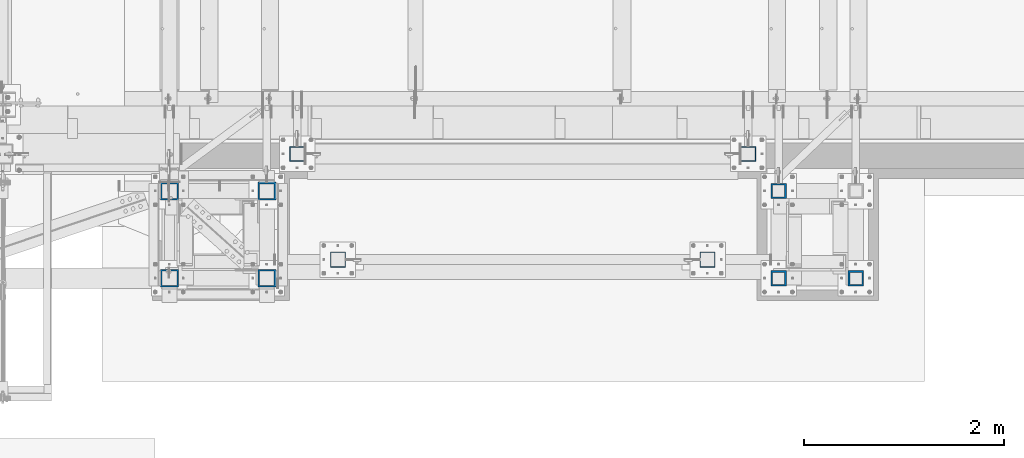
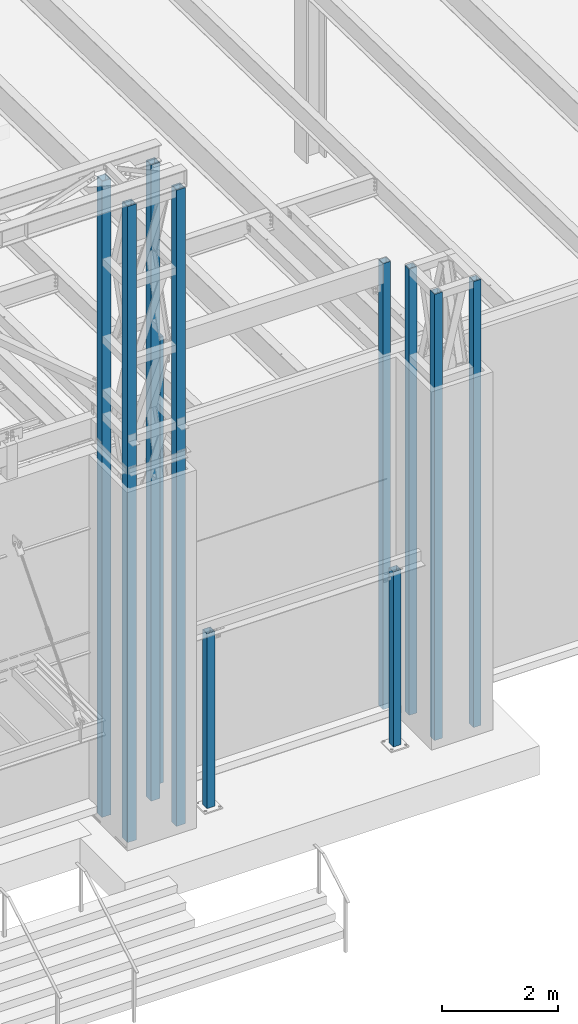
# One storey, part 895 of 1763: 11 columns, 6 elements without a shape of their own.
"""IFC2X3 building model written with IfcOpenShell, lengths in millimetres."""

from ifc_helpers import new_model, si_unit, frame, origin_with_axes, place, context, subcontext, project, spatial, faceted_brep, material, type_object, element, aggregate, save


model = new_model("IFC2X3")

# Units and contexts
model_context = context("Model", 3, precision=1e-05, world=origin_with_axes())
body_context = subcontext(model_context, "Body", "Model", "MODEL_VIEW")
ifc_project = project(units=[si_unit("LENGTHUNIT", "METRE", prefix="MILLI"), si_unit("AREAUNIT", "SQUARE_METRE"), si_unit("VOLUMEUNIT", "CUBIC_METRE"), si_unit("MASSUNIT", "GRAM", prefix="KILO"), si_unit("TIMEUNIT", "SECOND"), si_unit("PLANEANGLEUNIT", "RADIAN"), si_unit("SOLIDANGLEUNIT", "STERADIAN"), si_unit("THERMODYNAMICTEMPERATUREUNIT", "DEGREE_CELSIUS"), si_unit("LUMINOUSINTENSITYUNIT", "LUMEN")], contexts=[model_context])

# Site, building, storey
site_placement = place(None, origin_with_axes())
site = spatial("IfcSite", under=ifc_project, at=site_placement, CompositionType="ELEMENT")
building_placement = place(site_placement, origin_with_axes())
building = spatial("IfcBuilding", under=site, at=building_placement, Name="Undefined", CompositionType="ELEMENT")
storey_placement = place(building_placement, origin_with_axes())
storey = spatial("IfcBuildingStorey", under=building, at=storey_placement, Name="Undefined", CompositionType="ELEMENT", Elevation=0.0)

# Assembly, columns
assembly_1_placement = place(storey_placement, origin_with_axes())
assembly_1 = element("IfcElementAssembly", 1, at=assembly_1_placement, inside=storey, Name="FRAME", AssemblyPlace="NOTDEFINED", PredefinedType="RIGID_FRAME")
ifc_material = material()
column_type_1 = type_object("IfcColumnType", Name="HSS6X6X5/8", PredefinedType="NOTDEFINED")
column_1_placement = place(assembly_1_placement, frame((-41639.5634959181, -14579.5306029674, 5029.2), z_axis=(0.0, 1.0, 0.0), x_axis=(0.0, 0.0, 1.0)))
column_1 = element("IfcColumn", 2, at=column_1_placement, type_object=column_type_1, material=ifc_material, Name="COLUMN", ObjectType="HSS6X6X5/8", context=body_context, shape_type="Brep", body=[
    faceted_brep([(63.4999999999973, 60.3249999999971, -60.3250000000007), (63.4999999999973, -60.3249999999971, -60.3250000000007), (9429.74999873329, -60.3250000149637, -60.3250000000007), (9429.75000126672, 60.3249999850377, -60.3250000000007), (63.4999999999973, -60.3249999999971, 60.3250000000007), (9429.74999873329, -60.3250000149637, 60.3250000000007), (63.4999999999973, 60.3249999999971, 60.3250000000007), (9429.75000126672, 60.3249999850377, 60.3250000000007), (63.4999999999973, 76.1999999999971, -76.2000000000007), (63.4999999999973, 76.1999999999971, 76.2000000000007), (9429.75000000001, 76.1999999999971, 76.2000000000007), (9429.75000000001, 76.1999999999971, -76.2000000000007), (63.4999999999973, -76.1999999999971, 76.2000000000007), (9429.75000000001, -76.1999999999971, 76.2000000000007), (63.4999999999973, -76.1999999999971, -76.2000000000007), (9429.75000000001, -76.1999999999971, -76.2000000000007)], [[[0, 1, 2, 3]], [[1, 4, 5, 2]], [[4, 6, 7, 5]], [[6, 0, 3, 7]], [[8, 9, 10, 11]], [[9, 12, 13, 10]], [[12, 14, 15, 13]], [[14, 8, 11, 15]], [[13, 15, 11, 10], [5, 7, 3, 2]], [[14, 12, 9, 8], [6, 4, 1, 0]]]),
])
column_2_placement = place(assembly_1_placement, frame((-40868.0383006056, -15452.6556029674, 5029.2), z_axis=(0.0, 1.0, 0.0), x_axis=(0.0, 0.0, 1.0)))
column_2 = element("IfcColumn", 3, at=column_2_placement, type_object=column_type_1, material=ifc_material, Name="COLUMN", ObjectType="HSS6X6X5/8", context=body_context, shape_type="Brep", body=[
    faceted_brep([(63.4999999999973, 60.3249999999971, -60.3250000000007), (63.4999999999973, -60.3249999999971, -60.3250000000007), (9429.74999873329, -60.3250000149637, -60.3250000000007), (9429.75000126672, 60.3249999850377, -60.3250000000007), (63.4999999999973, -60.3249999999971, 60.3250000000007), (9429.74999873329, -60.3250000149637, 60.3250000000007), (63.4999999999973, 60.3249999999971, 60.3250000000007), (9429.75000126672, 60.3249999850377, 60.3250000000007), (63.4999999999973, 76.1999999999971, -76.2000000000007), (63.4999999999973, 76.1999999999971, 76.2000000000007), (9429.75000000001, 76.1999999999971, 76.2000000000007), (9429.75000000001, 76.1999999999971, -76.2000000000007), (63.4999999999973, -76.1999999999971, 76.2000000000007), (9429.75000000001, -76.1999999999971, 76.2000000000007), (63.4999999999973, -76.1999999999971, -76.2000000000007), (9429.75000000001, -76.1999999999971, -76.2000000000007)], [[[0, 1, 2, 3]], [[1, 4, 5, 2]], [[4, 6, 7, 5]], [[6, 0, 3, 7]], [[8, 9, 10, 11]], [[9, 12, 13, 10]], [[12, 14, 15, 13]], [[14, 8, 11, 15]], [[13, 15, 11, 10], [5, 7, 3, 2]], [[14, 12, 9, 8], [6, 4, 1, 0]]]),
])
column_3_placement = place(assembly_1_placement, frame((-41639.5634959181, -15452.6556029674, 5029.2), z_axis=(0.0, 1.0, 0.0), x_axis=(0.0, 0.0, 1.0)))
column_3 = element("IfcColumn", 4, at=column_3_placement, type_object=column_type_1, material=ifc_material, Name="FRAME", ObjectType="HSS6X6X5/8", context=body_context, shape_type="Brep", body=[
    faceted_brep([(63.4999999999973, 60.3249999999971, -60.3250000000007), (63.4999999999973, -60.3249999999971, -60.3250000000007), (9429.74999873329, -60.3250000149637, -60.3250000000007), (9429.75000126672, 60.3249999850377, -60.3250000000007), (63.4999999999973, -60.3249999999971, 60.3250000000007), (9429.74999873329, -60.3250000149637, 60.3250000000007), (63.4999999999973, 60.3249999999971, 60.3250000000007), (9429.75000126672, 60.3249999850377, 60.3250000000007), (63.4999999999973, 76.1999999999971, -76.2000000000007), (63.4999999999973, 76.1999999999971, 76.2000000000007), (9429.75000000001, 76.1999999999971, 76.2000000000007), (9429.75000000001, 76.1999999999971, -76.2000000000007), (63.4999999999973, -76.1999999999971, 76.2000000000007), (9429.75000000001, -76.1999999999971, 76.2000000000007), (63.4999999999973, -76.1999999999971, -76.2000000000007), (9429.75000000001, -76.1999999999971, -76.2000000000007)], [[[0, 1, 2, 3]], [[1, 4, 5, 2]], [[4, 6, 7, 5]], [[6, 0, 3, 7]], [[8, 9, 10, 11]], [[9, 12, 13, 10]], [[12, 14, 15, 13]], [[14, 8, 11, 15]], [[13, 15, 11, 10], [5, 7, 3, 2]], [[14, 12, 9, 8], [6, 4, 1, 0]]]),
])
aggregate(assembly_1, [column_1, column_2, column_3])

# Assembly, column
assembly_2_placement = place(storey_placement, origin_with_axes())
assembly_2 = element("IfcElementAssembly", 5, at=assembly_2_placement, inside=storey, Name="COLUMN", AssemblyPlace="NOTDEFINED", PredefinedType="RIGID_FRAME")
column_type_2 = type_object("IfcColumnType", Name="HSS6X6X3/8", PredefinedType="NOTDEFINED")
column_4_placement = place(assembly_2_placement, frame((-46456.4555979689, -14208.1264769908, 5029.2), z_axis=(0.0, 1.0, 0.0), x_axis=(0.0, 0.0, 1.0)))
column_4 = element("IfcColumn", 6, at=column_4_placement, type_object=column_type_2, material=ifc_material, Name="COLUMN", ObjectType="HSS6X6X3/8", context=body_context, shape_type="Brep", body=[
    faceted_brep([(63.5000000000027, 66.6750000000029, -66.6749999999993), (63.5000000000027, -66.6750000000029, -66.6749999999993), (9429.75000000001, -66.6750000000029, -66.6749999999993), (9429.75000000001, 66.6750000000029, -66.6749999999993), (63.5000000000027, -66.6750000000029, 66.6749999999993), (9429.75000000001, -66.6750000000029, 66.6749999999993), (63.5000000000027, 66.6750000000029, 66.6749999999993), (9429.75000000001, 66.6750000000029, 66.6749999999993), (63.4999999999973, 76.1999999999971, -76.2000000000007), (63.4999999999973, 76.1999999999971, 76.2000000000007), (9429.75000000001, 76.1999999999971, 76.2000000000007), (9429.75000000001, 76.1999999999971, -76.2000000000007), (63.4999999999973, -76.1999999999971, 76.2000000000007), (9429.75000000001, -76.1999999999971, 76.2000000000007), (63.4999999999973, -76.1999999999971, -76.2000000000007), (9429.75000000001, -76.1999999999971, -76.2000000000007)], [[[0, 1, 2, 3]], [[1, 4, 5, 2]], [[4, 6, 7, 5]], [[6, 0, 3, 7]], [[8, 9, 10, 11]], [[9, 12, 13, 10]], [[12, 14, 15, 13]], [[14, 8, 11, 15]], [[13, 15, 11, 10], [5, 7, 3, 2]], [[14, 12, 9, 8], [6, 4, 1, 0]]]),
])
aggregate(assembly_2, [column_4])

assembly_3_placement = place(storey_placement, origin_with_axes())
assembly_3 = element("IfcElementAssembly", 7, at=assembly_3_placement, inside=storey, Name="COLUMN", AssemblyPlace="NOTDEFINED", PredefinedType="RIGID_FRAME")
column_5_placement = place(assembly_3_placement, frame((-41944.780256172, -14208.1264769908, 5029.2), z_axis=(0.0, 1.0, 0.0), x_axis=(0.0, 0.0, 1.0)))
column_5 = element("IfcColumn", 8, at=column_5_placement, type_object=column_type_2, material=ifc_material, Name="COLUMN", ObjectType="HSS6X6X3/8", context=body_context, shape_type="Brep", body=[
    faceted_brep([(63.5000000000027, 66.6750000000029, -66.6749999999993), (63.5000000000027, -66.6750000000029, -66.6749999999993), (9429.75000000001, -66.6750000000029, -66.6749999999993), (9429.75000000001, 66.6750000000029, -66.6749999999993), (63.5000000000027, -66.6750000000029, 66.6749999999993), (9429.75000000001, -66.6750000000029, 66.6749999999993), (63.5000000000027, 66.6750000000029, 66.6749999999993), (9429.75000000001, 66.6750000000029, 66.6749999999993), (63.4999999999973, 76.1999999999971, -76.2000000000007), (63.4999999999973, 76.1999999999971, 76.2000000000007), (9429.75000000001, 76.1999999999971, 76.2000000000007), (9429.75000000001, 76.1999999999971, -76.2000000000007), (63.4999999999973, -76.1999999999971, 76.2000000000007), (9429.75000000001, -76.1999999999971, 76.2000000000007), (63.4999999999973, -76.1999999999971, -76.2000000000007), (9429.75000000001, -76.1999999999971, -76.2000000000007)], [[[0, 1, 2, 3]], [[1, 4, 5, 2]], [[4, 6, 7, 5]], [[6, 0, 3, 7]], [[8, 9, 10, 11]], [[9, 12, 13, 10]], [[12, 14, 15, 13]], [[14, 8, 11, 15]], [[13, 15, 11, 10], [5, 7, 3, 2]], [[14, 12, 9, 8], [6, 4, 1, 0]]]),
])
aggregate(assembly_3, [column_5])

# Assembly, columns
assembly_4_placement = place(storey_placement, origin_with_axes())
assembly_4 = element("IfcElementAssembly", 9, at=assembly_4_placement, inside=storey, Name="FRAME", AssemblyPlace="NOTDEFINED", PredefinedType="RIGID_FRAME")
column_type_3 = type_object("IfcColumnType", Name="HSS7X7X5/8", PredefinedType="NOTDEFINED")
column_6_placement = place(assembly_4_placement, frame((-46760.8272044142, -14579.6022094127, 5029.2), z_axis=(0.0, 1.0, 0.0), x_axis=(0.0, 0.0, 1.0)))
column_6 = element("IfcColumn", 10, at=column_6_placement, type_object=column_type_3, material=ifc_material, Name="FRAME", ObjectType="HSS7X7X5/8", context=body_context, shape_type="Brep", body=[
    faceted_brep([(63.5000000000009, 73.0250000000015, -73.0249999999996), (63.5000000000009, -73.0250000000015, -73.0249999999996), (13420.725, -73.0250000000015, -73.0249999999996), (13420.725, 73.0250000000015, -73.0249999999996), (63.5000000000009, -73.0250000000015, 73.0249999999996), (13420.725, -73.0250000000015, 73.0249999999996), (63.5000000000009, 73.0250000000015, 73.0249999999996), (13420.725, 73.0250000000015, 73.0249999999996), (63.5000000000009, 88.9000000000015, -88.8999999999996), (63.5000000000009, 88.9000000000015, 88.8999999999996), (13420.725, 88.9000000000015, 88.8999999999996), (13420.725, 88.9000000000015, -88.8999999999996), (63.5000000000009, -88.9000000000015, 88.8999999999996), (13420.725, -88.9000000000015, 88.8999999999996), (63.5000000000009, -88.9000000000015, -88.8999999999996), (13420.725, -88.9000000000015, -88.8999999999996)], [[[0, 1, 2, 3]], [[1, 4, 5, 2]], [[4, 6, 7, 5]], [[6, 0, 3, 7]], [[8, 9, 10, 11]], [[9, 12, 13, 10]], [[12, 14, 15, 13]], [[14, 8, 11, 15]], [[13, 15, 11, 10], [5, 7, 3, 2]], [[14, 12, 9, 8], [6, 4, 1, 0]]]),
])
column_7_placement = place(assembly_4_placement, frame((-47735.5523997267, -14579.6022094127, 5029.2), z_axis=(0.0, 1.0, 0.0), x_axis=(0.0, 0.0, 1.0)))
column_7 = element("IfcColumn", 11, at=column_7_placement, type_object=column_type_3, material=ifc_material, Name="FRAME", ObjectType="HSS7X7X5/8", context=body_context, shape_type="Brep", body=[
    faceted_brep([(63.5000000000009, 73.0250000000015, -73.0249999999996), (63.5000000000009, -73.0250000000015, -73.0249999999996), (13420.725, -73.0250000000015, -73.0249999999996), (13420.725, 73.0250000000015, -73.0249999999996), (63.5000000000009, -73.0250000000015, 73.0249999999996), (13420.725, -73.0250000000015, 73.0249999999996), (63.5000000000009, 73.0250000000015, 73.0249999999996), (13420.725, 73.0250000000015, 73.0249999999996), (63.5000000000009, 88.9000000000015, -88.8999999999996), (63.5000000000009, 88.9000000000015, 88.8999999999996), (13420.725, 88.9000000000015, 88.8999999999996), (13420.725, 88.9000000000015, -88.8999999999996), (63.5000000000009, -88.9000000000015, 88.8999999999996), (13420.725, -88.9000000000015, 88.8999999999996), (63.5000000000009, -88.9000000000015, -88.8999999999996), (13420.725, -88.9000000000015, -88.8999999999996)], [[[0, 1, 2, 3]], [[1, 4, 5, 2]], [[4, 6, 7, 5]], [[6, 0, 3, 7]], [[8, 9, 10, 11]], [[9, 12, 13, 10]], [[12, 14, 15, 13]], [[14, 8, 11, 15]], [[13, 15, 11, 10], [5, 7, 3, 2]], [[14, 12, 9, 8], [6, 4, 1, 0]]]),
])
column_8_placement = place(assembly_4_placement, frame((-46760.8272044142, -15452.7272094127, 5029.2), z_axis=(0.0, 1.0, 0.0), x_axis=(0.0, 0.0, 1.0)))
column_8 = element("IfcColumn", 12, at=column_8_placement, type_object=column_type_3, material=ifc_material, Name="FRAME", ObjectType="HSS7X7X5/8", context=body_context, shape_type="Brep", body=[
    faceted_brep([(63.5000000000009, 73.0250000000015, -73.0249999999996), (63.5000000000009, -73.0250000000015, -73.0249999999996), (13420.725, -73.0250000000015, -73.0249999999996), (13420.725, 73.0250000000015, -73.0249999999996), (63.5000000000009, -73.0250000000015, 73.0249999999996), (13420.725, -73.0250000000015, 73.0249999999996), (63.5000000000009, 73.0250000000015, 73.0249999999996), (13420.725, 73.0250000000015, 73.0249999999996), (63.5000000000009, 88.9000000000015, -88.8999999999996), (63.5000000000009, 88.9000000000015, 88.8999999999996), (13420.725, 88.9000000000015, 88.8999999999996), (13420.725, 88.9000000000015, -88.8999999999996), (63.5000000000009, -88.9000000000015, 88.8999999999996), (13420.725, -88.9000000000015, 88.8999999999996), (63.5000000000009, -88.9000000000015, -88.8999999999996), (13420.725, -88.9000000000015, -88.8999999999996)], [[[0, 1, 2, 3]], [[1, 4, 5, 2]], [[4, 6, 7, 5]], [[6, 0, 3, 7]], [[8, 9, 10, 11]], [[9, 12, 13, 10]], [[12, 14, 15, 13]], [[14, 8, 11, 15]], [[13, 15, 11, 10], [5, 7, 3, 2]], [[14, 12, 9, 8], [6, 4, 1, 0]]]),
])
column_9_placement = place(assembly_4_placement, frame((-47735.5523997267, -15452.7272094127, 5029.2), z_axis=(0.0, 1.0, 0.0), x_axis=(0.0, 0.0, 1.0)))
column_9 = element("IfcColumn", 13, at=column_9_placement, type_object=column_type_3, material=ifc_material, Name="FRAME", ObjectType="HSS7X7X5/8", context=body_context, shape_type="Brep", body=[
    faceted_brep([(63.5000000000009, 73.0250000000015, -73.0249999999996), (63.5000000000009, -73.0250000000015, -73.0249999999996), (13420.725, -73.0250000000015, -73.0249999999996), (13420.725, 73.0250000000015, -73.0249999999996), (63.5000000000009, -73.0250000000015, 73.0249999999996), (13420.725, -73.0250000000015, 73.0249999999996), (63.5000000000009, 73.0250000000015, 73.0249999999996), (13420.725, 73.0250000000015, 73.0249999999996), (63.5000000000009, 88.9000000000015, -88.8999999999996), (63.5000000000009, 88.9000000000015, 88.8999999999996), (13420.725, 88.9000000000015, 88.8999999999996), (13420.725, 88.9000000000015, -88.8999999999996), (63.5000000000009, -88.9000000000015, 88.8999999999996), (13420.725, -88.9000000000015, 88.8999999999996), (63.5000000000009, -88.9000000000015, -88.8999999999996), (13420.725, -88.9000000000015, -88.8999999999996)], [[[0, 1, 2, 3]], [[1, 4, 5, 2]], [[4, 6, 7, 5]], [[6, 0, 3, 7]], [[8, 9, 10, 11]], [[9, 12, 13, 10]], [[12, 14, 15, 13]], [[14, 8, 11, 15]], [[13, 15, 11, 10], [5, 7, 3, 2]], [[14, 12, 9, 8], [6, 4, 1, 0]]]),
])
aggregate(assembly_4, [column_6, column_7, column_8, column_9])

# Assembly, column
assembly_5_placement = place(storey_placement, origin_with_axes())
assembly_5 = element("IfcElementAssembly", 14, at=assembly_5_placement, inside=storey, Name="COLUMN", AssemblyPlace="NOTDEFINED", PredefinedType="RIGID_FRAME")
column_type_4 = type_object("IfcColumnType", Name="HSS6X6X1/4", PredefinedType="NOTDEFINED")
column_10_placement = place(assembly_5_placement, frame((-42351.1710444319, -15265.4000613784, 5029.2), z_axis=(0.0, 1.0, 0.0), x_axis=(0.0, 0.0, 1.0)))
column_10 = element("IfcColumn", 15, at=column_10_placement, type_object=column_type_4, material=ifc_material, Name="COLUMN", ObjectType="HSS6X6X1/4", context=body_context, shape_type="Brep", body=[
    faceted_brep([(63.4999999999973, 69.8499999999985, -69.8500000000004), (63.4999999999973, -69.8499999999985, -69.8500000000004), (3740.15, -69.8499999999985, -69.8500000000004), (3740.15, 69.8499999999985, -69.8500000000004), (63.4999999999973, -69.8499999999985, 69.8500000000004), (3740.15, -69.8499999999985, 69.8500000000004), (63.4999999999973, 69.8499999999985, 69.8500000000004), (3740.15, 69.8499999999985, 69.8500000000004), (63.4999999999973, 76.1999999999971, -76.2000000000007), (63.4999999999973, 76.1999999999971, 76.2000000000007), (3740.15, 76.1999999999971, 76.2000000000007), (3740.15, 76.1999999999971, -76.2000000000007), (63.4999999999973, -76.1999999999971, 76.2000000000007), (3740.15, -76.1999999999971, 76.2000000000007), (63.4999999999973, -76.1999999999971, -76.2000000000007), (3740.15, -76.1999999999971, -76.2000000000007)], [[[0, 1, 2, 3]], [[1, 4, 5, 2]], [[4, 6, 7, 5]], [[6, 0, 3, 7]], [[8, 9, 10, 11]], [[9, 12, 13, 10]], [[12, 14, 15, 13]], [[14, 8, 11, 15]], [[13, 15, 11, 10], [5, 7, 3, 2]], [[14, 12, 9, 8], [6, 4, 1, 0]]]),
])
aggregate(assembly_5, [column_10])

assembly_6_placement = place(storey_placement, origin_with_axes())
assembly_6 = element("IfcElementAssembly", 16, at=assembly_6_placement, inside=storey, Name="COLUMN", AssemblyPlace="NOTDEFINED", PredefinedType="RIGID_FRAME")
column_11_placement = place(assembly_6_placement, frame((-46049.6371287306, -15265.4000613784, 5029.2), z_axis=(0.0, 1.0, 0.0), x_axis=(0.0, 0.0, 1.0)))
column_11 = element("IfcColumn", 17, at=column_11_placement, type_object=column_type_4, material=ifc_material, Name="COLUMN", ObjectType="HSS6X6X1/4", context=body_context, shape_type="Brep", body=[
    faceted_brep([(63.4999999999973, 69.8499999999985, -69.8500000000004), (63.4999999999973, -69.8499999999985, -69.8500000000004), (3740.15, -69.8499999999985, -69.8500000000004), (3740.15, 69.8499999999985, -69.8500000000004), (63.4999999999973, -69.8499999999985, 69.8500000000004), (3740.15, -69.8499999999985, 69.8500000000004), (63.4999999999973, 69.8499999999985, 69.8500000000004), (3740.15, 69.8499999999985, 69.8500000000004), (63.4999999999973, 76.1999999999971, -76.2000000000007), (63.4999999999973, 76.1999999999971, 76.2000000000007), (3740.15, 76.1999999999971, 76.2000000000007), (3740.15, 76.1999999999971, -76.2000000000007), (63.4999999999973, -76.1999999999971, 76.2000000000007), (3740.15, -76.1999999999971, 76.2000000000007), (63.4999999999973, -76.1999999999971, -76.2000000000007), (3740.15, -76.1999999999971, -76.2000000000007)], [[[0, 1, 2, 3]], [[1, 4, 5, 2]], [[4, 6, 7, 5]], [[6, 0, 3, 7]], [[8, 9, 10, 11]], [[9, 12, 13, 10]], [[12, 14, 15, 13]], [[14, 8, 11, 15]], [[13, 15, 11, 10], [5, 7, 3, 2]], [[14, 12, 9, 8], [6, 4, 1, 0]]]),
])
aggregate(assembly_6, [column_11])

save(model, "model.ifc")
